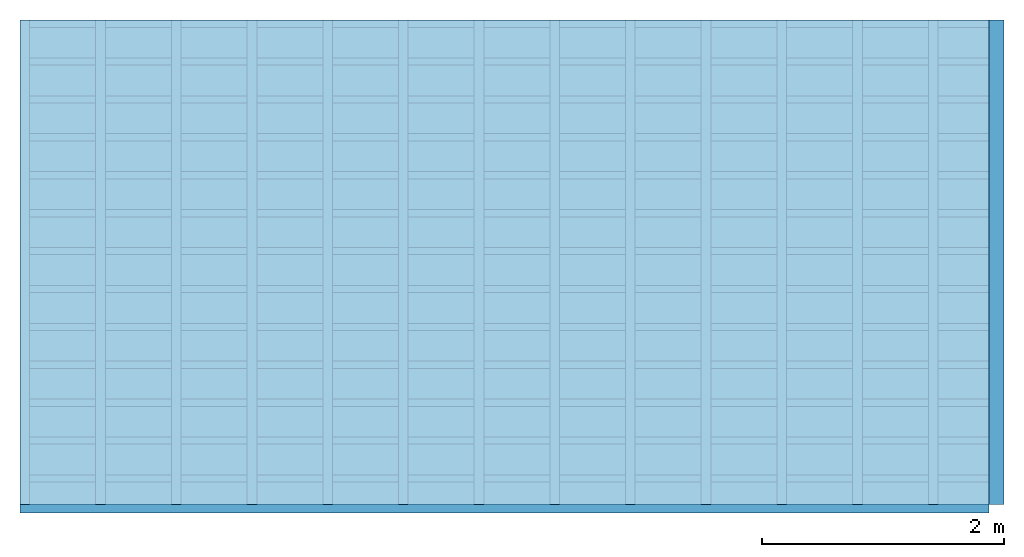
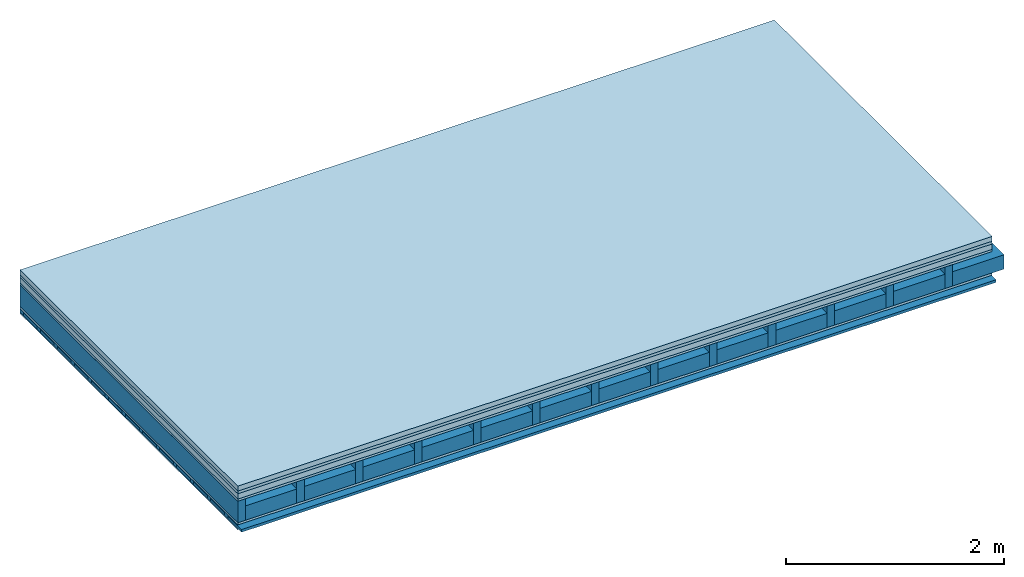
# One storey: 6 plates, 4 members, 1 element without a shape of its own.
"""IFC4 building model written with IfcOpenShell, lengths in metres."""

from ifc_helpers import new_model, si_unit, derived_unit, direction, frame, frame_2d, origin, origin_with_axes, place, context, project, spatial, rectangle, extrude, material, layer, layer_set, type_object, element, aggregate, save


model = new_model("IFC4")

# Units and contexts
plan_context = context("Plan", 3, precision=1e-05, world=origin(), true_north=direction((0.0, 1.0)))
model_context = context("Model", 3, precision=1e-05, world=origin(), true_north=direction((0.0, 1.0)))
ifc_project = project(units=[si_unit("LENGTHUNIT", "METRE"), derived_unit("SOUNDPRESSUREUNIT", [(si_unit("PRESSUREUNIT", "PASCAL", prefix="MICRO"), 0)]), si_unit("ENERGYUNIT", "JOULE", prefix="MEGA"), si_unit("MASSUNIT", "GRAM", prefix="KILO"), derived_unit("THERMALTRANSMITTANCEUNIT", [(si_unit("POWERUNIT", "WATT"), 1), (si_unit("AREAUNIT", "SQUARE_METRE"), -1), (si_unit("THERMODYNAMICTEMPERATUREUNIT", "KELVIN"), -1)]), derived_unit("AREADENSITYUNIT", [(si_unit("MASSUNIT", "GRAM", prefix="KILO"), 1), (si_unit("AREAUNIT", "SQUARE_METRE"), -1)]), derived_unit("USERDEFINED", [(si_unit("ENERGYUNIT", "JOULE", prefix="MEGA"), 1), (si_unit("AREAUNIT", "SQUARE_METRE"), -1)])], contexts=[plan_context, model_context])

# Site, building, storey
site = spatial("IfcSite", under=ifc_project)
building_placement = place(None, origin())
building = spatial("IfcBuilding", under=site, at=building_placement)
storey_placement = place(building_placement, origin())
storey = spatial("IfcBuildingStorey", under=building, at=storey_placement)

# Slab, members, plates
ifc_material_1 = material(Category="04.005")
ifc_layer_1 = layer(ifc_material_1, 0.055, Name="On-material")
ifc_material_2 = material()
ifc_layer_2 = layer(ifc_material_2, 0.03, Name="Impact sound insulation")
ifc_material_3 = material(Name="Cement panels, glued on sub-floor", Category="02.007")
ifc_layer_3 = layer(ifc_material_3, 0.06, Name="on Supporting structure")
ifc_material_4 = material(Category="07.001")
ifc_layer_4 = layer(ifc_material_4, 0.025, Name="Sub-floor")
ifc_material_5 = material(Name="Rigid, of the art")
ifc_layer_5 = layer(ifc_material_5, 0.0, Name="Bond")
ifc_layer_6 = layer(None, 0.24, Name="Supporting structure")
ifc_layer_7 = layer(ifc_material_5, 0.0, Name="Bond")
ifc_layer_8 = layer(ifc_material_4, 0.025, Name="Lower layer 1")
ifc_layer_9 = layer(None, 0.04, Name="Battens / profiles")
ifc_material_6 = material(Category="03.007")
ifc_layer_10 = layer(ifc_material_6, 0.015, Name="Ceiling covering 1st layer")
ifc_material_7 = material(Name="Glued joints")
ifc_layer_11 = layer(ifc_material_7, 0.0, Name="Surface / treatment")
ifc_layer_set = layer_set([ifc_layer_1, ifc_layer_2, ifc_layer_3, ifc_layer_4, ifc_layer_5, ifc_layer_6, ifc_layer_7, ifc_layer_8, ifc_layer_9, ifc_layer_10, ifc_layer_11])
slab_type = type_object("IfcSlabType", Name="A0470", PredefinedType="NOTDEFINED", material=ifc_layer_set)
slab_placement = place(None, frame((0.0, 0.0, 0.0), z_axis=(0.0, 0.0, -1.0), x_axis=(1.0, 0.0, 0.0)))
slab = element("IfcSlab", 1, at=slab_placement, inside=storey, type_object=slab_type, material=ifc_layer_set, Name="Slab #1")
ifc_material_8 = material()
member_1_placement = place(slab_placement, origin())
member_1 = element("IfcMember", 2, at=member_1_placement, material=ifc_material_8, Name="Supporting structure", context=plan_context, shape_type="SweptSolid", body=[
    extrude(rectangle(XDim=0.08, YDim=0.24, at=frame_2d((0.04, 0.12), x_axis=(1.0, 0.0))), frame((0.0, 4.0, 0.17), z_axis=(0.0, -1.0, 0.0), x_axis=(1.0, 0.0, 0.0)), (0.0, 0.0, 1.0), 4.0),
    extrude(rectangle(XDim=0.08, YDim=0.24, at=frame_2d((0.04, 0.12), x_axis=(1.0, 0.0))), frame((0.625, 4.0, 0.17), z_axis=(0.0, -1.0, 0.0), x_axis=(1.0, 0.0, 0.0)), (0.0, 0.0, 1.0), 4.0),
    extrude(rectangle(XDim=0.08, YDim=0.24, at=frame_2d((0.04, 0.12), x_axis=(1.0, 0.0))), frame((1.25, 4.0, 0.17), z_axis=(0.0, -1.0, 0.0), x_axis=(1.0, 0.0, 0.0)), (0.0, 0.0, 1.0), 4.0),
    extrude(rectangle(XDim=0.08, YDim=0.24, at=frame_2d((0.04, 0.12), x_axis=(1.0, 0.0))), frame((1.875, 4.0, 0.17), z_axis=(0.0, -1.0, 0.0), x_axis=(1.0, 0.0, 0.0)), (0.0, 0.0, 1.0), 4.0),
    extrude(rectangle(XDim=0.08, YDim=0.24, at=frame_2d((0.04, 0.12), x_axis=(1.0, 0.0))), frame((2.5, 4.0, 0.17), z_axis=(0.0, -1.0, 0.0), x_axis=(1.0, 0.0, 0.0)), (0.0, 0.0, 1.0), 4.0),
    extrude(rectangle(XDim=0.08, YDim=0.24, at=frame_2d((0.04, 0.12), x_axis=(1.0, 0.0))), frame((3.125, 4.0, 0.17), z_axis=(0.0, -1.0, 0.0), x_axis=(1.0, 0.0, 0.0)), (0.0, 0.0, 1.0), 4.0),
    extrude(rectangle(XDim=0.08, YDim=0.24, at=frame_2d((0.04, 0.12), x_axis=(1.0, 0.0))), frame((3.75, 4.0, 0.17), z_axis=(0.0, -1.0, 0.0), x_axis=(1.0, 0.0, 0.0)), (0.0, 0.0, 1.0), 4.0),
    extrude(rectangle(XDim=0.08, YDim=0.24, at=frame_2d((0.04, 0.12), x_axis=(1.0, 0.0))), frame((4.375, 4.0, 0.17), z_axis=(0.0, -1.0, 0.0), x_axis=(1.0, 0.0, 0.0)), (0.0, 0.0, 1.0), 4.0),
    extrude(rectangle(XDim=0.08, YDim=0.24, at=frame_2d((0.04, 0.12), x_axis=(1.0, 0.0))), frame((5.0, 4.0, 0.17), z_axis=(0.0, -1.0, 0.0), x_axis=(1.0, 0.0, 0.0)), (0.0, 0.0, 1.0), 4.0),
    extrude(rectangle(XDim=0.08, YDim=0.24, at=frame_2d((0.04, 0.12), x_axis=(1.0, 0.0))), frame((5.625, 4.0, 0.17), z_axis=(0.0, -1.0, 0.0), x_axis=(1.0, 0.0, 0.0)), (0.0, 0.0, 1.0), 4.0),
    extrude(rectangle(XDim=0.08, YDim=0.24, at=frame_2d((0.04, 0.12), x_axis=(1.0, 0.0))), frame((6.25, 4.0, 0.17), z_axis=(0.0, -1.0, 0.0), x_axis=(1.0, 0.0, 0.0)), (0.0, 0.0, 1.0), 4.0),
    extrude(rectangle(XDim=0.08, YDim=0.24, at=frame_2d((0.04, 0.12), x_axis=(1.0, 0.0))), frame((6.875, 4.0, 0.17), z_axis=(0.0, -1.0, 0.0), x_axis=(1.0, 0.0, 0.0)), (0.0, 0.0, 1.0), 4.0),
    extrude(rectangle(XDim=0.08, YDim=0.24, at=frame_2d((0.04, 0.12), x_axis=(1.0, 0.0))), frame((7.5, 4.0, 0.17), z_axis=(0.0, -1.0, 0.0), x_axis=(1.0, 0.0, 0.0)), (0.0, 0.0, 1.0), 4.0),
])
ifc_material_9 = material()
member_2_placement = place(slab_placement, origin())
member_2 = element("IfcMember", 3, at=member_2_placement, material=ifc_material_9, Name="Cavity", context=plan_context, shape_type="SweptSolid", body=[
    extrude(rectangle(XDim=0.545, YDim=0.16, at=frame_2d((0.2725, 0.08), x_axis=(1.0, 0.0))), frame((0.08, 4.0, 0.25), z_axis=(0.0, -1.0, 0.0), x_axis=(1.0, 0.0, 0.0)), (0.0, 0.0, 1.0), 4.0),
    extrude(rectangle(XDim=0.545, YDim=0.16, at=frame_2d((0.2725, 0.08), x_axis=(1.0, 0.0))), frame((0.705, 4.0, 0.25), z_axis=(0.0, -1.0, 0.0), x_axis=(1.0, 0.0, 0.0)), (0.0, 0.0, 1.0), 4.0),
    extrude(rectangle(XDim=0.545, YDim=0.16, at=frame_2d((0.2725, 0.08), x_axis=(1.0, 0.0))), frame((1.33, 4.0, 0.25), z_axis=(0.0, -1.0, 0.0), x_axis=(1.0, 0.0, 0.0)), (0.0, 0.0, 1.0), 4.0),
    extrude(rectangle(XDim=0.545, YDim=0.16, at=frame_2d((0.2725, 0.08), x_axis=(1.0, 0.0))), frame((1.955, 4.0, 0.25), z_axis=(0.0, -1.0, 0.0), x_axis=(1.0, 0.0, 0.0)), (0.0, 0.0, 1.0), 4.0),
    extrude(rectangle(XDim=0.545, YDim=0.16, at=frame_2d((0.2725, 0.08), x_axis=(1.0, 0.0))), frame((2.58, 4.0, 0.25), z_axis=(0.0, -1.0, 0.0), x_axis=(1.0, 0.0, 0.0)), (0.0, 0.0, 1.0), 4.0),
    extrude(rectangle(XDim=0.545, YDim=0.16, at=frame_2d((0.2725, 0.08), x_axis=(1.0, 0.0))), frame((3.205, 4.0, 0.25), z_axis=(0.0, -1.0, 0.0), x_axis=(1.0, 0.0, 0.0)), (0.0, 0.0, 1.0), 4.0),
    extrude(rectangle(XDim=0.545, YDim=0.16, at=frame_2d((0.2725, 0.08), x_axis=(1.0, 0.0))), frame((3.83, 4.0, 0.25), z_axis=(0.0, -1.0, 0.0), x_axis=(1.0, 0.0, 0.0)), (0.0, 0.0, 1.0), 4.0),
    extrude(rectangle(XDim=0.545, YDim=0.16, at=frame_2d((0.2725, 0.08), x_axis=(1.0, 0.0))), frame((4.455, 4.0, 0.25), z_axis=(0.0, -1.0, 0.0), x_axis=(1.0, 0.0, 0.0)), (0.0, 0.0, 1.0), 4.0),
    extrude(rectangle(XDim=0.545, YDim=0.16, at=frame_2d((0.2725, 0.08), x_axis=(1.0, 0.0))), frame((5.08, 4.0, 0.25), z_axis=(0.0, -1.0, 0.0), x_axis=(1.0, 0.0, 0.0)), (0.0, 0.0, 1.0), 4.0),
    extrude(rectangle(XDim=0.545, YDim=0.16, at=frame_2d((0.2725, 0.08), x_axis=(1.0, 0.0))), frame((5.705, 4.0, 0.25), z_axis=(0.0, -1.0, 0.0), x_axis=(1.0, 0.0, 0.0)), (0.0, 0.0, 1.0), 4.0),
    extrude(rectangle(XDim=0.545, YDim=0.16, at=frame_2d((0.2725, 0.08), x_axis=(1.0, 0.0))), frame((6.33, 4.0, 0.25), z_axis=(0.0, -1.0, 0.0), x_axis=(1.0, 0.0, 0.0)), (0.0, 0.0, 1.0), 4.0),
    extrude(rectangle(XDim=0.545, YDim=0.16, at=frame_2d((0.2725, 0.08), x_axis=(1.0, 0.0))), frame((6.955, 4.0, 0.25), z_axis=(0.0, -1.0, 0.0), x_axis=(1.0, 0.0, 0.0)), (0.0, 0.0, 1.0), 4.0),
    extrude(rectangle(XDim=0.545, YDim=0.16, at=frame_2d((0.2725, 0.08), x_axis=(1.0, 0.0))), frame((7.58, 4.0, 0.25), z_axis=(0.0, -1.0, 0.0), x_axis=(1.0, 0.0, 0.0)), (0.0, 0.0, 1.0), 4.0),
])
ifc_material_10 = material()
member_3_placement = place(slab_placement, origin())
member_3 = element("IfcMember", 4, at=member_3_placement, material=ifc_material_10, Name="Battens / profiles", context=plan_context, shape_type="SweptSolid", body=[
    extrude(rectangle(XDim=0.06, YDim=0.04, at=frame_2d((0.03, 0.02), x_axis=(1.0, 0.0))), frame((0.0, 0.0, 0.435), z_axis=(1.0, 0.0, 0.0), x_axis=(0.0, 1.0, 0.0)), (0.0, 0.0, 1.0), 8.0),
    extrude(rectangle(XDim=0.06, YDim=0.04, at=frame_2d((0.03, 0.02), x_axis=(1.0, 0.0))), frame((0.0, 0.313, 0.435), z_axis=(1.0, 0.0, 0.0), x_axis=(0.0, 1.0, 0.0)), (0.0, 0.0, 1.0), 8.0),
    extrude(rectangle(XDim=0.06, YDim=0.04, at=frame_2d((0.03, 0.02), x_axis=(1.0, 0.0))), frame((0.0, 0.626, 0.435), z_axis=(1.0, 0.0, 0.0), x_axis=(0.0, 1.0, 0.0)), (0.0, 0.0, 1.0), 8.0),
    extrude(rectangle(XDim=0.06, YDim=0.04, at=frame_2d((0.03, 0.02), x_axis=(1.0, 0.0))), frame((0.0, 0.939, 0.435), z_axis=(1.0, 0.0, 0.0), x_axis=(0.0, 1.0, 0.0)), (0.0, 0.0, 1.0), 8.0),
    extrude(rectangle(XDim=0.06, YDim=0.04, at=frame_2d((0.03, 0.02), x_axis=(1.0, 0.0))), frame((0.0, 1.252, 0.435), z_axis=(1.0, 0.0, 0.0), x_axis=(0.0, 1.0, 0.0)), (0.0, 0.0, 1.0), 8.0),
    extrude(rectangle(XDim=0.06, YDim=0.04, at=frame_2d((0.03, 0.02), x_axis=(1.0, 0.0))), frame((0.0, 1.565, 0.435), z_axis=(1.0, 0.0, 0.0), x_axis=(0.0, 1.0, 0.0)), (0.0, 0.0, 1.0), 8.0),
    extrude(rectangle(XDim=0.06, YDim=0.04, at=frame_2d((0.03, 0.02), x_axis=(1.0, 0.0))), frame((0.0, 1.878, 0.435), z_axis=(1.0, 0.0, 0.0), x_axis=(0.0, 1.0, 0.0)), (0.0, 0.0, 1.0), 8.0),
    extrude(rectangle(XDim=0.06, YDim=0.04, at=frame_2d((0.03, 0.02), x_axis=(1.0, 0.0))), frame((0.0, 2.191, 0.435), z_axis=(1.0, 0.0, 0.0), x_axis=(0.0, 1.0, 0.0)), (0.0, 0.0, 1.0), 8.0),
    extrude(rectangle(XDim=0.06, YDim=0.04, at=frame_2d((0.03, 0.02), x_axis=(1.0, 0.0))), frame((0.0, 2.504, 0.435), z_axis=(1.0, 0.0, 0.0), x_axis=(0.0, 1.0, 0.0)), (0.0, 0.0, 1.0), 8.0),
    extrude(rectangle(XDim=0.06, YDim=0.04, at=frame_2d((0.03, 0.02), x_axis=(1.0, 0.0))), frame((0.0, 2.817, 0.435), z_axis=(1.0, 0.0, 0.0), x_axis=(0.0, 1.0, 0.0)), (0.0, 0.0, 1.0), 8.0),
    extrude(rectangle(XDim=0.06, YDim=0.04, at=frame_2d((0.03, 0.02), x_axis=(1.0, 0.0))), frame((0.0, 3.13, 0.435), z_axis=(1.0, 0.0, 0.0), x_axis=(0.0, 1.0, 0.0)), (0.0, 0.0, 1.0), 8.0),
    extrude(rectangle(XDim=0.06, YDim=0.04, at=frame_2d((0.03, 0.02), x_axis=(1.0, 0.0))), frame((0.0, 3.443, 0.435), z_axis=(1.0, 0.0, 0.0), x_axis=(0.0, 1.0, 0.0)), (0.0, 0.0, 1.0), 8.0),
    extrude(rectangle(XDim=0.06, YDim=0.04, at=frame_2d((0.03, 0.02), x_axis=(1.0, 0.0))), frame((0.0, 3.756, 0.435), z_axis=(1.0, 0.0, 0.0), x_axis=(0.0, 1.0, 0.0)), (0.0, 0.0, 1.0), 8.0),
])
member_4_placement = place(slab_placement, origin())
member_4 = element("IfcMember", 5, at=member_4_placement, material=ifc_material_9, Name="Cavity", context=plan_context, shape_type="SweptSolid", body=[
    extrude(rectangle(XDim=0.253, YDim=0.03, at=frame_2d((0.1265, 0.015), x_axis=(1.0, 0.0))), frame((0.0, 0.06, 0.445), z_axis=(1.0, 0.0, 0.0), x_axis=(0.0, 1.0, 0.0)), (0.0, 0.0, 1.0), 8.0),
    extrude(rectangle(XDim=0.253, YDim=0.03, at=frame_2d((0.1265, 0.015), x_axis=(1.0, 0.0))), frame((0.0, 0.373, 0.445), z_axis=(1.0, 0.0, 0.0), x_axis=(0.0, 1.0, 0.0)), (0.0, 0.0, 1.0), 8.0),
    extrude(rectangle(XDim=0.253, YDim=0.03, at=frame_2d((0.1265, 0.015), x_axis=(1.0, 0.0))), frame((0.0, 0.686, 0.445), z_axis=(1.0, 0.0, 0.0), x_axis=(0.0, 1.0, 0.0)), (0.0, 0.0, 1.0), 8.0),
    extrude(rectangle(XDim=0.253, YDim=0.03, at=frame_2d((0.1265, 0.015), x_axis=(1.0, 0.0))), frame((0.0, 0.999, 0.445), z_axis=(1.0, 0.0, 0.0), x_axis=(0.0, 1.0, 0.0)), (0.0, 0.0, 1.0), 8.0),
    extrude(rectangle(XDim=0.253, YDim=0.03, at=frame_2d((0.1265, 0.015), x_axis=(1.0, 0.0))), frame((0.0, 1.312, 0.445), z_axis=(1.0, 0.0, 0.0), x_axis=(0.0, 1.0, 0.0)), (0.0, 0.0, 1.0), 8.0),
    extrude(rectangle(XDim=0.253, YDim=0.03, at=frame_2d((0.1265, 0.015), x_axis=(1.0, 0.0))), frame((0.0, 1.625, 0.445), z_axis=(1.0, 0.0, 0.0), x_axis=(0.0, 1.0, 0.0)), (0.0, 0.0, 1.0), 8.0),
    extrude(rectangle(XDim=0.253, YDim=0.03, at=frame_2d((0.1265, 0.015), x_axis=(1.0, 0.0))), frame((0.0, 1.938, 0.445), z_axis=(1.0, 0.0, 0.0), x_axis=(0.0, 1.0, 0.0)), (0.0, 0.0, 1.0), 8.0),
    extrude(rectangle(XDim=0.253, YDim=0.03, at=frame_2d((0.1265, 0.015), x_axis=(1.0, 0.0))), frame((0.0, 2.251, 0.445), z_axis=(1.0, 0.0, 0.0), x_axis=(0.0, 1.0, 0.0)), (0.0, 0.0, 1.0), 8.0),
    extrude(rectangle(XDim=0.253, YDim=0.03, at=frame_2d((0.1265, 0.015), x_axis=(1.0, 0.0))), frame((0.0, 2.564, 0.445), z_axis=(1.0, 0.0, 0.0), x_axis=(0.0, 1.0, 0.0)), (0.0, 0.0, 1.0), 8.0),
    extrude(rectangle(XDim=0.253, YDim=0.03, at=frame_2d((0.1265, 0.015), x_axis=(1.0, 0.0))), frame((0.0, 2.877, 0.445), z_axis=(1.0, 0.0, 0.0), x_axis=(0.0, 1.0, 0.0)), (0.0, 0.0, 1.0), 8.0),
    extrude(rectangle(XDim=0.253, YDim=0.03, at=frame_2d((0.1265, 0.015), x_axis=(1.0, 0.0))), frame((0.0, 3.19, 0.445), z_axis=(1.0, 0.0, 0.0), x_axis=(0.0, 1.0, 0.0)), (0.0, 0.0, 1.0), 8.0),
    extrude(rectangle(XDim=0.253, YDim=0.03, at=frame_2d((0.1265, 0.015), x_axis=(1.0, 0.0))), frame((0.0, 3.503, 0.445), z_axis=(1.0, 0.0, 0.0), x_axis=(0.0, 1.0, 0.0)), (0.0, 0.0, 1.0), 8.0),
    extrude(rectangle(XDim=0.253, YDim=0.03, at=frame_2d((0.1265, 0.015), x_axis=(1.0, 0.0))), frame((0.0, 3.816, 0.445), z_axis=(1.0, 0.0, 0.0), x_axis=(0.0, 1.0, 0.0)), (0.0, 0.0, 1.0), 8.0),
])
plate_1_placement = place(slab_placement, origin())
plate_1 = element("IfcPlate", 6, at=plate_1_placement, material=ifc_material_1, Name="On-material", context=plan_context, shape_type="SweptSolid", body=[
    extrude(rectangle(XDim=8.0, YDim=4.0, at=frame_2d((4.0, 2.0), x_axis=(1.0, 0.0))), origin_with_axes(), (0.0, 0.0, 1.0), 0.055),
])
plate_2_placement = place(slab_placement, origin())
plate_2 = element("IfcPlate", 7, at=plate_2_placement, material=ifc_material_2, Name="Impact sound insulation", context=plan_context, shape_type="SweptSolid", body=[
    extrude(rectangle(XDim=8.0, YDim=4.0, at=frame_2d((4.0, 2.0), x_axis=(1.0, 0.0))), frame((0.0, 0.0, 0.055), z_axis=(0.0, 0.0, 1.0), x_axis=(1.0, 0.0, 0.0)), (0.0, 0.0, 1.0), 0.03),
])
plate_3_placement = place(slab_placement, origin())
plate_3 = element("IfcPlate", 8, at=plate_3_placement, material=ifc_material_3, Name="on Supporting structure", context=plan_context, shape_type="SweptSolid", body=[
    extrude(rectangle(XDim=8.0, YDim=4.0, at=frame_2d((4.0, 2.0), x_axis=(1.0, 0.0))), frame((0.0, 0.0, 0.085), z_axis=(0.0, 0.0, 1.0), x_axis=(1.0, 0.0, 0.0)), (0.0, 0.0, 1.0), 0.06),
])
plate_4_placement = place(slab_placement, origin())
plate_4 = element("IfcPlate", 9, at=plate_4_placement, material=ifc_material_4, Name="Sub-floor", context=plan_context, shape_type="SweptSolid", body=[
    extrude(rectangle(XDim=8.0, YDim=4.0, at=frame_2d((4.0, 2.0), x_axis=(1.0, 0.0))), frame((0.0, 0.0, 0.145), z_axis=(0.0, 0.0, 1.0), x_axis=(1.0, 0.0, 0.0)), (0.0, 0.0, 1.0), 0.025),
])
plate_5_placement = place(slab_placement, origin())
plate_5 = element("IfcPlate", 10, at=plate_5_placement, material=ifc_material_4, Name="Lower layer 1", context=plan_context, shape_type="SweptSolid", body=[
    extrude(rectangle(XDim=8.0, YDim=4.0, at=frame_2d((4.0, 2.0), x_axis=(1.0, 0.0))), frame((0.0, 0.0, 0.41), z_axis=(0.0, 0.0, 1.0), x_axis=(1.0, 0.0, 0.0)), (0.0, 0.0, 1.0), 0.025),
])
plate_6_placement = place(slab_placement, origin())
plate_6 = element("IfcPlate", 11, at=plate_6_placement, material=ifc_material_6, Name="Ceiling covering 1st layer", context=plan_context, shape_type="SweptSolid", body=[
    extrude(rectangle(XDim=8.0, YDim=4.0, at=frame_2d((4.0, 2.0), x_axis=(1.0, 0.0))), frame((0.0, 0.0, 0.475), z_axis=(0.0, 0.0, 1.0), x_axis=(1.0, 0.0, 0.0)), (0.0, 0.0, 1.0), 0.015),
])
aggregate(slab, [plate_1, plate_2, plate_3, plate_4, member_1, member_2, plate_5, member_3, member_4, plate_6])

save(model, "model.ifc")
